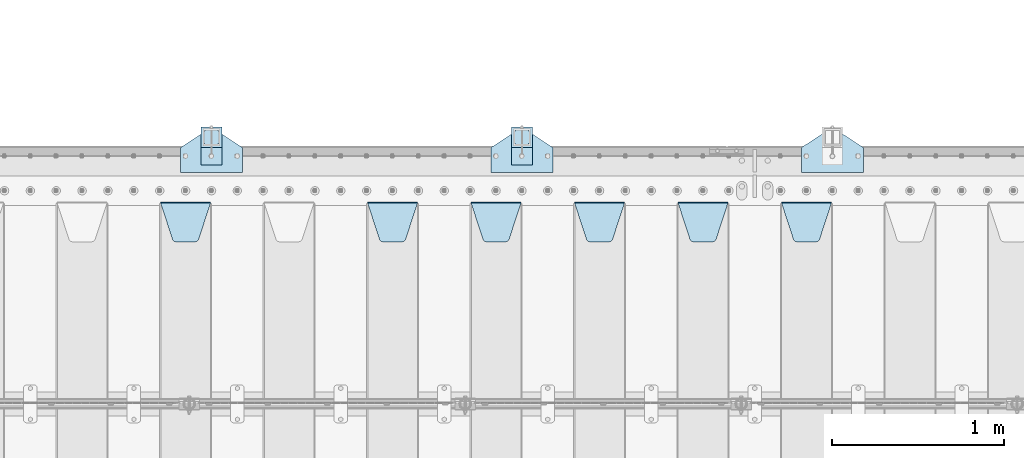
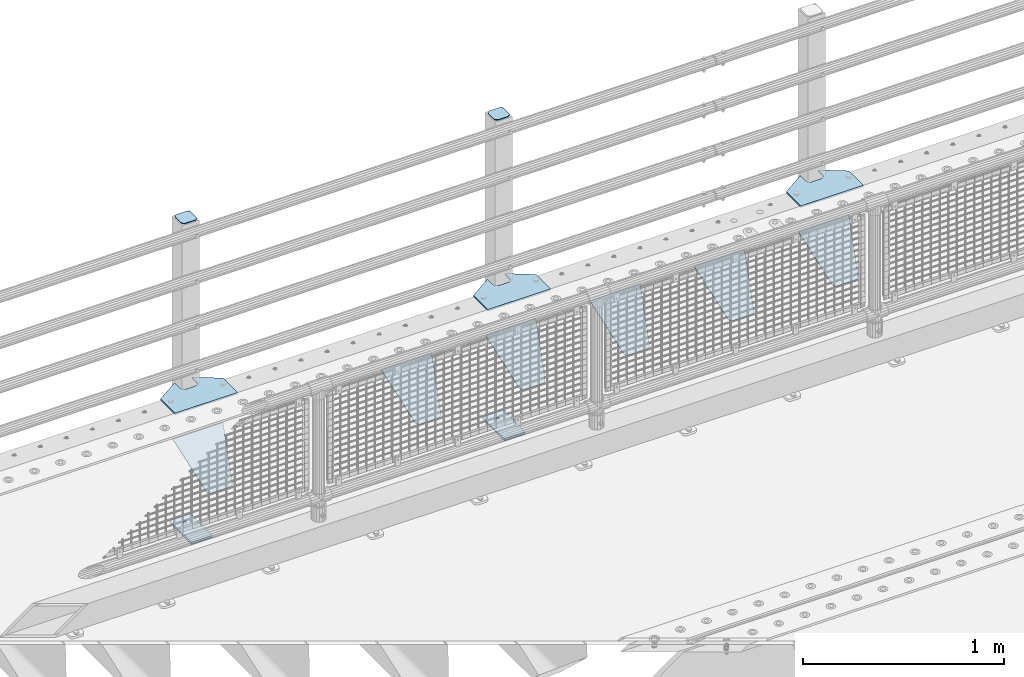
# One storey, part 223 of 257: 15 plates.
"""IFC2X3 building model written with IfcOpenShell, lengths in millimetres."""

from ifc_helpers import new_model, si_unit, frame, origin_with_axes, place, context, subcontext, project, spatial, faceted_brep, material, type_object, element, save


model = new_model("IFC2X3")

# Units and contexts
model_context = context("Model", 3, precision=1e-05, world=origin_with_axes())
body_context = subcontext(model_context, "Body", "Model", "MODEL_VIEW")
ifc_project = project(units=[si_unit("LENGTHUNIT", "METRE", prefix="MILLI"), si_unit("AREAUNIT", "SQUARE_METRE"), si_unit("VOLUMEUNIT", "CUBIC_METRE"), si_unit("MASSUNIT", "GRAM", prefix="KILO"), si_unit("TIMEUNIT", "SECOND"), si_unit("PLANEANGLEUNIT", "RADIAN"), si_unit("SOLIDANGLEUNIT", "STERADIAN"), si_unit("THERMODYNAMICTEMPERATUREUNIT", "DEGREE_CELSIUS"), si_unit("LUMINOUSINTENSITYUNIT", "LUMEN")], contexts=[model_context])

# Site, building, storey
site_placement = place(None, origin_with_axes())
site = spatial("IfcSite", under=ifc_project, at=site_placement, CompositionType="ELEMENT")
building_placement = place(site_placement, origin_with_axes())
building = spatial("IfcBuilding", under=site, at=building_placement, Name="Standard", CompositionType="ELEMENT")
storey_placement = place(building_placement, origin_with_axes())
storey = spatial("IfcBuildingStorey", under=building, at=storey_placement, Name="Undefined", CompositionType="ELEMENT", Elevation=0.0)

# Plates
ifc_material_1 = material(Name="STEEL/S355N")
plate_type_1 = type_object("IfcPlateType", PredefinedType="NOTDEFINED")
plate_1_placement = place(storey_placement, frame((48105.0, 11831.7677669559, -1.767766952965), z_axis=(0.0, -0.707106781186548, -0.707106781186547), x_axis=(1.0, 0.0, 0.0)))
element("IfcPlate", 1, at=plate_1_placement, inside=storey, type_object=plate_type_1, material=ifc_material_1, context=body_context, shape_type="Brep", body=[
    faceted_brep([(0.0, -2.5, 0.0), (69.345504679477, -2.50000000000091, 300.17173142483), (69.345504679477, 2.5, 300.171731424831), (0.0, 2.5, 0.0), (70.927406119954, -2.50000000000091, 304.8974424154), (70.927406119954, 2.5, 304.8974424154), (73.3818627772271, -2.50000000000091, 309.234538108527), (73.3818627772271, 2.49999999999909, 309.234538108527), (76.6187032999587, -2.5, 313.023683126103), (76.6187032999587, 2.5, 313.023683126103), (80.5190132705029, -2.5, 316.125672595372), (80.5190132705029, 2.5, 316.125672595371), (84.9395038596849, -2.5, 318.426546230476), (84.9395038596849, 2.5, 318.426546230477), (89.7177759439219, -2.5, 319.841774983275), (89.7177759439219, 2.5, 319.841774983275), (94.6782862926484, -2.5, 320.319366455079), (94.6782862926484, 2.5, 320.319366455079), (195.321713707352, -2.5, 320.319366455079), (195.321713707352, 2.5, 320.319366455079), (200.282224056078, -2.5, 319.841774983275), (200.282224056078, 2.49999999999909, 319.841774983275), (205.060496140315, -2.5, 318.426546230476), (205.060496140315, 2.49999999999909, 318.426546230475), (209.480986729497, -2.5, 316.125672595371), (209.480986729497, 2.5, 316.125672595371), (213.381296700041, -2.50000000000091, 313.023683126102), (213.381296700041, 2.5, 313.023683126103), (216.618137222766, -2.50000000000091, 309.234538108527), (216.618137222766, 2.5, 309.234538108527), (219.072593880039, -2.5, 304.897442415399), (219.072593880039, 2.5, 304.897442415399), (220.654495320523, -2.50000000000091, 300.17173142483), (220.654495320523, 2.5, 300.171731424831), (290.0, -2.50000000000091, 0.0), (290.0, 2.5, 9.09494701772928e-13)], [[[0, 1, 2, 3]], [[1, 4, 5, 2]], [[4, 6, 7, 5]], [[6, 8, 9, 7]], [[8, 10, 11, 9]], [[10, 12, 13, 11]], [[12, 14, 15, 13]], [[14, 16, 17, 15]], [[16, 18, 19, 17]], [[18, 20, 21, 19]], [[20, 22, 23, 21]], [[22, 24, 25, 23]], [[24, 26, 27, 25]], [[26, 28, 29, 27]], [[28, 30, 31, 29]], [[30, 32, 33, 31]], [[32, 34, 35, 33]], [[34, 0, 3, 35]], [[5, 7, 9, 11, 13, 15, 17, 19, 21, 23, 25, 27, 29, 31, 33, 35, 3, 2]], [[34, 32, 30, 28, 26, 24, 22, 20, 18, 16, 14, 12, 10, 8, 6, 4, 1, 0]]]),
])
plate_2_placement = place(storey_placement, frame((47505.0, 11831.7677669559, -1.767766952965), z_axis=(0.0, -0.707106781186548, -0.707106781186547), x_axis=(1.0, 0.0, 0.0)))
element("IfcPlate", 2, at=plate_2_placement, inside=storey, type_object=plate_type_1, material=ifc_material_1, context=body_context, shape_type="Brep", body=[
    faceted_brep([(0.0, -2.5, 0.0), (69.345504679477, -2.50000000000091, 300.17173142483), (69.345504679477, 2.5, 300.171731424831), (0.0, 2.5, 0.0), (70.927406119954, -2.50000000000091, 304.8974424154), (70.927406119954, 2.5, 304.8974424154), (73.3818627772271, -2.50000000000091, 309.234538108527), (73.3818627772271, 2.49999999999909, 309.234538108527), (76.6187032999587, -2.5, 313.023683126103), (76.6187032999587, 2.5, 313.023683126103), (80.5190132705029, -2.5, 316.125672595372), (80.5190132705029, 2.5, 316.125672595371), (84.9395038596849, -2.5, 318.426546230476), (84.9395038596849, 2.5, 318.426546230477), (89.7177759439219, -2.5, 319.841774983275), (89.7177759439219, 2.5, 319.841774983275), (94.6782862926484, -2.5, 320.319366455079), (94.6782862926484, 2.5, 320.319366455079), (195.321713707352, -2.5, 320.319366455079), (195.321713707352, 2.5, 320.319366455079), (200.282224056078, -2.5, 319.841774983275), (200.282224056078, 2.49999999999909, 319.841774983275), (205.060496140315, -2.5, 318.426546230476), (205.060496140315, 2.49999999999909, 318.426546230475), (209.480986729497, -2.5, 316.125672595371), (209.480986729497, 2.5, 316.125672595371), (213.381296700041, -2.50000000000091, 313.023683126102), (213.381296700041, 2.5, 313.023683126103), (216.618137222766, -2.50000000000091, 309.234538108527), (216.618137222766, 2.5, 309.234538108527), (219.072593880039, -2.5, 304.897442415399), (219.072593880039, 2.5, 304.897442415399), (220.654495320523, -2.50000000000091, 300.17173142483), (220.654495320523, 2.5, 300.171731424831), (290.0, -2.50000000000091, 0.0), (290.0, 2.5, 9.09494701772928e-13)], [[[0, 1, 2, 3]], [[1, 4, 5, 2]], [[4, 6, 7, 5]], [[6, 8, 9, 7]], [[8, 10, 11, 9]], [[10, 12, 13, 11]], [[12, 14, 15, 13]], [[14, 16, 17, 15]], [[16, 18, 19, 17]], [[18, 20, 21, 19]], [[20, 22, 23, 21]], [[22, 24, 25, 23]], [[24, 26, 27, 25]], [[26, 28, 29, 27]], [[28, 30, 31, 29]], [[30, 32, 33, 31]], [[32, 34, 35, 33]], [[34, 0, 3, 35]], [[5, 7, 9, 11, 13, 15, 17, 19, 21, 23, 25, 27, 29, 31, 33, 35, 3, 2]], [[34, 32, 30, 28, 26, 24, 22, 20, 18, 16, 14, 12, 10, 8, 6, 4, 1, 0]]]),
])
plate_3_placement = place(storey_placement, frame((46905.0, 11831.7677669559, -1.767766952965), z_axis=(0.0, -0.707106781186548, -0.707106781186547), x_axis=(1.0, 0.0, 0.0)))
element("IfcPlate", 3, at=plate_3_placement, inside=storey, type_object=plate_type_1, material=ifc_material_1, context=body_context, shape_type="Brep", body=[
    faceted_brep([(0.0, -2.5, 0.0), (69.345504679477, -2.50000000000091, 300.17173142483), (69.345504679477, 2.5, 300.171731424831), (0.0, 2.5, 0.0), (70.927406119954, -2.50000000000091, 304.8974424154), (70.927406119954, 2.5, 304.8974424154), (73.3818627772271, -2.50000000000091, 309.234538108527), (73.3818627772271, 2.49999999999909, 309.234538108527), (76.6187032999587, -2.5, 313.023683126103), (76.6187032999587, 2.5, 313.023683126103), (80.5190132705029, -2.5, 316.125672595372), (80.5190132705029, 2.5, 316.125672595371), (84.9395038596849, -2.5, 318.426546230476), (84.9395038596849, 2.5, 318.426546230477), (89.7177759439219, -2.5, 319.841774983275), (89.7177759439219, 2.5, 319.841774983275), (94.6782862926484, -2.5, 320.319366455079), (94.6782862926484, 2.5, 320.319366455079), (195.321713707352, -2.5, 320.319366455079), (195.321713707352, 2.5, 320.319366455079), (200.282224056078, -2.5, 319.841774983275), (200.282224056078, 2.49999999999909, 319.841774983275), (205.060496140315, -2.5, 318.426546230476), (205.060496140315, 2.49999999999909, 318.426546230475), (209.480986729497, -2.5, 316.125672595371), (209.480986729497, 2.5, 316.125672595371), (213.381296700041, -2.50000000000091, 313.023683126102), (213.381296700041, 2.5, 313.023683126103), (216.618137222766, -2.50000000000091, 309.234538108527), (216.618137222766, 2.5, 309.234538108527), (219.072593880039, -2.5, 304.897442415399), (219.072593880039, 2.5, 304.897442415399), (220.654495320523, -2.50000000000091, 300.17173142483), (220.654495320523, 2.5, 300.171731424831), (290.0, -2.50000000000091, 0.0), (290.0, 2.5, 9.09494701772928e-13)], [[[0, 1, 2, 3]], [[1, 4, 5, 2]], [[4, 6, 7, 5]], [[6, 8, 9, 7]], [[8, 10, 11, 9]], [[10, 12, 13, 11]], [[12, 14, 15, 13]], [[14, 16, 17, 15]], [[16, 18, 19, 17]], [[18, 20, 21, 19]], [[20, 22, 23, 21]], [[22, 24, 25, 23]], [[24, 26, 27, 25]], [[26, 28, 29, 27]], [[28, 30, 31, 29]], [[30, 32, 33, 31]], [[32, 34, 35, 33]], [[34, 0, 3, 35]], [[5, 7, 9, 11, 13, 15, 17, 19, 21, 23, 25, 27, 29, 31, 33, 35, 3, 2]], [[34, 32, 30, 28, 26, 24, 22, 20, 18, 16, 14, 12, 10, 8, 6, 4, 1, 0]]]),
])
plate_4_placement = place(storey_placement, frame((46305.0, 11831.7677669559, -1.767766952965), z_axis=(0.0, -0.707106781186548, -0.707106781186547), x_axis=(1.0, 0.0, 0.0)))
element("IfcPlate", 4, at=plate_4_placement, inside=storey, type_object=plate_type_1, material=ifc_material_1, context=body_context, shape_type="Brep", body=[
    faceted_brep([(0.0, -2.5, 0.0), (69.345504679477, -2.50000000000091, 300.17173142483), (69.345504679477, 2.5, 300.171731424831), (0.0, 2.5, 0.0), (70.927406119954, -2.50000000000091, 304.8974424154), (70.927406119954, 2.5, 304.8974424154), (73.3818627772271, -2.50000000000091, 309.234538108527), (73.3818627772271, 2.49999999999909, 309.234538108527), (76.6187032999587, -2.5, 313.023683126103), (76.6187032999587, 2.5, 313.023683126103), (80.5190132705029, -2.5, 316.125672595372), (80.5190132705029, 2.5, 316.125672595371), (84.9395038596849, -2.5, 318.426546230476), (84.9395038596849, 2.5, 318.426546230477), (89.7177759439219, -2.5, 319.841774983275), (89.7177759439219, 2.5, 319.841774983275), (94.6782862926484, -2.5, 320.319366455079), (94.6782862926484, 2.5, 320.319366455079), (195.321713707352, -2.5, 320.319366455079), (195.321713707352, 2.5, 320.319366455079), (200.282224056078, -2.5, 319.841774983275), (200.282224056078, 2.49999999999909, 319.841774983275), (205.060496140315, -2.5, 318.426546230476), (205.060496140315, 2.49999999999909, 318.426546230475), (209.480986729497, -2.5, 316.125672595371), (209.480986729497, 2.5, 316.125672595371), (213.381296700041, -2.50000000000091, 313.023683126102), (213.381296700041, 2.5, 313.023683126103), (216.618137222766, -2.50000000000091, 309.234538108527), (216.618137222766, 2.5, 309.234538108527), (219.072593880039, -2.5, 304.897442415399), (219.072593880039, 2.5, 304.897442415399), (220.654495320523, -2.50000000000091, 300.17173142483), (220.654495320523, 2.5, 300.171731424831), (290.0, -2.50000000000091, 0.0), (290.0, 2.5, 9.09494701772928e-13)], [[[0, 1, 2, 3]], [[1, 4, 5, 2]], [[4, 6, 7, 5]], [[6, 8, 9, 7]], [[8, 10, 11, 9]], [[10, 12, 13, 11]], [[12, 14, 15, 13]], [[14, 16, 17, 15]], [[16, 18, 19, 17]], [[18, 20, 21, 19]], [[20, 22, 23, 21]], [[22, 24, 25, 23]], [[24, 26, 27, 25]], [[26, 28, 29, 27]], [[28, 30, 31, 29]], [[30, 32, 33, 31]], [[32, 34, 35, 33]], [[34, 0, 3, 35]], [[5, 7, 9, 11, 13, 15, 17, 19, 21, 23, 25, 27, 29, 31, 33, 35, 3, 2]], [[34, 32, 30, 28, 26, 24, 22, 20, 18, 16, 14, 12, 10, 8, 6, 4, 1, 0]]]),
])
plate_5_placement = place(storey_placement, frame((45705.0, 11831.7677669559, -1.767766952965), z_axis=(0.0, -0.707106781186548, -0.707106781186547), x_axis=(1.0, 0.0, 0.0)))
element("IfcPlate", 5, at=plate_5_placement, inside=storey, type_object=plate_type_1, material=ifc_material_1, context=body_context, shape_type="Brep", body=[
    faceted_brep([(0.0, -2.5, 0.0), (69.345504679477, -2.50000000000091, 300.17173142483), (69.345504679477, 2.5, 300.171731424831), (0.0, 2.5, 0.0), (70.927406119954, -2.50000000000091, 304.8974424154), (70.927406119954, 2.5, 304.8974424154), (73.3818627772271, -2.50000000000091, 309.234538108527), (73.3818627772271, 2.49999999999909, 309.234538108527), (76.6187032999587, -2.5, 313.023683126103), (76.6187032999587, 2.5, 313.023683126103), (80.5190132705029, -2.5, 316.125672595372), (80.5190132705029, 2.5, 316.125672595371), (84.9395038596849, -2.5, 318.426546230476), (84.9395038596849, 2.5, 318.426546230477), (89.7177759439219, -2.5, 319.841774983275), (89.7177759439219, 2.5, 319.841774983275), (94.6782862926484, -2.5, 320.319366455079), (94.6782862926484, 2.5, 320.319366455079), (195.321713707352, -2.5, 320.319366455079), (195.321713707352, 2.5, 320.319366455079), (200.282224056078, -2.5, 319.841774983275), (200.282224056078, 2.49999999999909, 319.841774983275), (205.060496140315, -2.5, 318.426546230476), (205.060496140315, 2.49999999999909, 318.426546230475), (209.480986729497, -2.5, 316.125672595371), (209.480986729497, 2.5, 316.125672595371), (213.381296700041, -2.50000000000091, 313.023683126102), (213.381296700041, 2.5, 313.023683126103), (216.618137222766, -2.50000000000091, 309.234538108527), (216.618137222766, 2.5, 309.234538108527), (219.072593880039, -2.5, 304.897442415399), (219.072593880039, 2.5, 304.897442415399), (220.654495320523, -2.50000000000091, 300.17173142483), (220.654495320523, 2.5, 300.171731424831), (290.0, -2.50000000000091, 0.0), (290.0, 2.5, 9.09494701772928e-13)], [[[0, 1, 2, 3]], [[1, 4, 5, 2]], [[4, 6, 7, 5]], [[6, 8, 9, 7]], [[8, 10, 11, 9]], [[10, 12, 13, 11]], [[12, 14, 15, 13]], [[14, 16, 17, 15]], [[16, 18, 19, 17]], [[18, 20, 21, 19]], [[20, 22, 23, 21]], [[22, 24, 25, 23]], [[24, 26, 27, 25]], [[26, 28, 29, 27]], [[28, 30, 31, 29]], [[30, 32, 33, 31]], [[32, 34, 35, 33]], [[34, 0, 3, 35]], [[5, 7, 9, 11, 13, 15, 17, 19, 21, 23, 25, 27, 29, 31, 33, 35, 3, 2]], [[34, 32, 30, 28, 26, 24, 22, 20, 18, 16, 14, 12, 10, 8, 6, 4, 1, 0]]]),
])
plate_6_placement = place(storey_placement, frame((44505.0, 11831.7677669559, -1.767766952965), z_axis=(0.0, -0.707106781186548, -0.707106781186547), x_axis=(1.0, 0.0, 0.0)))
element("IfcPlate", 6, at=plate_6_placement, inside=storey, type_object=plate_type_1, material=ifc_material_1, context=body_context, shape_type="Brep", body=[
    faceted_brep([(0.0, -2.5, 0.0), (69.345504679477, -2.50000000000091, 300.17173142483), (69.345504679477, 2.5, 300.171731424831), (0.0, 2.5, 0.0), (70.927406119954, -2.50000000000091, 304.8974424154), (70.927406119954, 2.5, 304.8974424154), (73.3818627772271, -2.50000000000091, 309.234538108527), (73.3818627772271, 2.49999999999909, 309.234538108527), (76.6187032999587, -2.5, 313.023683126103), (76.6187032999587, 2.5, 313.023683126103), (80.5190132705029, -2.5, 316.125672595372), (80.5190132705029, 2.5, 316.125672595371), (84.9395038596849, -2.5, 318.426546230476), (84.9395038596849, 2.5, 318.426546230477), (89.7177759439219, -2.5, 319.841774983275), (89.7177759439219, 2.5, 319.841774983275), (94.6782862926484, -2.5, 320.319366455079), (94.6782862926484, 2.5, 320.319366455079), (195.321713707352, -2.5, 320.319366455079), (195.321713707352, 2.5, 320.319366455079), (200.282224056078, -2.5, 319.841774983275), (200.282224056078, 2.49999999999909, 319.841774983275), (205.060496140315, -2.5, 318.426546230476), (205.060496140315, 2.49999999999909, 318.426546230475), (209.480986729497, -2.5, 316.125672595371), (209.480986729497, 2.5, 316.125672595371), (213.381296700041, -2.50000000000091, 313.023683126102), (213.381296700041, 2.5, 313.023683126103), (216.618137222766, -2.50000000000091, 309.234538108527), (216.618137222766, 2.5, 309.234538108527), (219.072593880039, -2.5, 304.897442415399), (219.072593880039, 2.5, 304.897442415399), (220.654495320523, -2.50000000000091, 300.17173142483), (220.654495320523, 2.5, 300.171731424831), (290.0, -2.50000000000091, 0.0), (290.0, 2.5, 9.09494701772928e-13)], [[[0, 1, 2, 3]], [[1, 4, 5, 2]], [[4, 6, 7, 5]], [[6, 8, 9, 7]], [[8, 10, 11, 9]], [[10, 12, 13, 11]], [[12, 14, 15, 13]], [[14, 16, 17, 15]], [[16, 18, 19, 17]], [[18, 20, 21, 19]], [[20, 22, 23, 21]], [[22, 24, 25, 23]], [[24, 26, 27, 25]], [[26, 28, 29, 27]], [[28, 30, 31, 29]], [[30, 32, 33, 31]], [[32, 34, 35, 33]], [[34, 0, 3, 35]], [[5, 7, 9, 11, 13, 15, 17, 19, 21, 23, 25, 27, 29, 31, 33, 35, 3, 2]], [[34, 32, 30, 28, 26, 24, 22, 20, 18, 16, 14, 12, 10, 8, 6, 4, 1, 0]]]),
])
ifc_material_2 = material(Name="STEEL/S355J2")
plate_type_2 = type_object("IfcPlateType", PredefinedType="NOTDEFINED")
plate_7_placement = place(storey_placement, frame((48220.0, 12005.0, 5.00000000004911), z_axis=(0.0, 1.0, 0.0), x_axis=(1.0, 0.0, 0.0)))
element("IfcPlate", 7, at=plate_7_placement, inside=storey, type_object=plate_type_2, material=ifc_material_2, context=body_context, shape_type="Brep", body=[
    faceted_brep([(0.0, -5.0, 0.0), (2.31396552408114e-06, -5.0, 145.0), (2.31396552408114e-06, 5.0, 145.0), (0.0, 5.0, 0.0), (130.0, -5.0, 230.0), (130.0, 5.0, 230.0), (130.0, -5.0, 180.0), (130.0, 5.0, 180.0), (130.48036798992, -5.0, 175.122741949597), (130.48036798992, 5.0, 175.122741949597), (131.903011687216, -5.0, 170.432914190873), (131.903011687216, 5.0, 170.432914190873), (134.213259692435, -5.0, 166.11074417451), (134.213259692435, 5.0, 166.11074417451), (137.322330470335, -5.0, 162.322330470337), (137.322330470335, 5.0, 162.322330470337), (141.110744174512, -5.0, 159.213259692437), (141.110744174512, 5.0, 159.213259692437), (145.432914190875, -5.0, 156.903011687218), (145.432914190875, 5.0, 156.903011687218), (150.122741949599, -5.0, 155.48036798992), (150.122741949599, 5.0, 155.48036798992), (155.0, -5.0, 155.0), (155.0, 5.0, 155.0), (205.0, -5.0, 155.0), (205.0, 5.0, 155.0), (209.877258050401, -5.0, 155.48036798992), (209.877258050401, 5.0, 155.48036798992), (214.567085809125, -5.0, 156.903011687218), (214.567085809125, 5.0, 156.903011687218), (218.889255825488, -5.0, 159.213259692437), (218.889255825488, 5.0, 159.213259692437), (222.677669529665, -5.0, 162.322330470337), (222.677669529665, 5.0, 162.322330470337), (225.786740307565, -5.0, 166.11074417451), (225.786740307565, 5.0, 166.11074417451), (228.096988312784, -5.0, 170.432914190873), (228.096988312784, 5.0, 170.432914190873), (229.51963201008, -5.0, 175.122741949597), (229.51963201008, 5.0, 175.122741949597), (230.0, -5.0, 180.0), (230.0, 5.0, 180.0), (230.0, -5.0, 230.0), (230.0, 5.0, 230.0), (360.0, -5.0, 145.0), (360.0, 5.0, 145.0), (360.0, -5.0, -7.27595761418343e-12), (360.0, 5.0, -7.27595761418343e-12)], [[[0, 1, 2, 3]], [[1, 4, 5, 2]], [[4, 6, 7, 5]], [[6, 8, 9, 7]], [[8, 10, 11, 9]], [[10, 12, 13, 11]], [[12, 14, 15, 13]], [[14, 16, 17, 15]], [[16, 18, 19, 17]], [[18, 20, 21, 19]], [[20, 22, 23, 21]], [[22, 24, 25, 23]], [[24, 26, 27, 25]], [[26, 28, 29, 27]], [[28, 30, 31, 29]], [[30, 32, 33, 31]], [[32, 34, 35, 33]], [[34, 36, 37, 35]], [[36, 38, 39, 37]], [[38, 40, 41, 39]], [[40, 42, 43, 41]], [[42, 44, 45, 43]], [[44, 46, 47, 45]], [[46, 0, 3, 47]], [[5, 7, 9, 11, 13, 15, 17, 19, 21, 23, 25, 27, 29, 31, 33, 35, 37, 39, 41, 43, 45, 47, 3, 2]], [[46, 44, 42, 40, 38, 36, 34, 32, 30, 28, 26, 24, 22, 20, 18, 16, 14, 12, 10, 8, 6, 4, 1, 0]]]),
])
plate_8_placement = place(storey_placement, frame((46420.0, 12005.0, 5.00000000004911), z_axis=(0.0, 1.0, 0.0), x_axis=(1.0, 0.0, 0.0)))
element("IfcPlate", 8, at=plate_8_placement, inside=storey, type_object=plate_type_2, material=ifc_material_2, context=body_context, shape_type="Brep", body=[
    faceted_brep([(0.0, -5.0, 0.0), (2.31396552408114e-06, -5.0, 145.0), (2.31396552408114e-06, 5.0, 145.0), (0.0, 5.0, 0.0), (130.0, -5.0, 230.0), (130.0, 5.0, 230.0), (130.0, -5.0, 180.0), (130.0, 5.0, 180.0), (130.48036798992, -5.0, 175.122741949597), (130.48036798992, 5.0, 175.122741949597), (131.903011687216, -5.0, 170.432914190873), (131.903011687216, 5.0, 170.432914190873), (134.213259692435, -5.0, 166.11074417451), (134.213259692435, 5.0, 166.11074417451), (137.322330470335, -5.0, 162.322330470337), (137.322330470335, 5.0, 162.322330470337), (141.110744174512, -5.0, 159.213259692437), (141.110744174512, 5.0, 159.213259692437), (145.432914190875, -5.0, 156.903011687218), (145.432914190875, 5.0, 156.903011687218), (150.122741949599, -5.0, 155.48036798992), (150.122741949599, 5.0, 155.48036798992), (155.0, -5.0, 155.0), (155.0, 5.0, 155.0), (205.0, -5.0, 155.0), (205.0, 5.0, 155.0), (209.877258050401, -5.0, 155.48036798992), (209.877258050401, 5.0, 155.48036798992), (214.567085809125, -5.0, 156.903011687218), (214.567085809125, 5.0, 156.903011687218), (218.889255825488, -5.0, 159.213259692437), (218.889255825488, 5.0, 159.213259692437), (222.677669529665, -5.0, 162.322330470337), (222.677669529665, 5.0, 162.322330470337), (225.786740307565, -5.0, 166.11074417451), (225.786740307565, 5.0, 166.11074417451), (228.096988312784, -5.0, 170.432914190873), (228.096988312784, 5.0, 170.432914190873), (229.51963201008, -5.0, 175.122741949597), (229.51963201008, 5.0, 175.122741949597), (230.0, -5.0, 180.0), (230.0, 5.0, 180.0), (230.0, -5.0, 230.0), (230.0, 5.0, 230.0), (360.0, -5.0, 145.0), (360.0, 5.0, 145.0), (360.0, -5.0, -7.27595761418343e-12), (360.0, 5.0, -7.27595761418343e-12)], [[[0, 1, 2, 3]], [[1, 4, 5, 2]], [[4, 6, 7, 5]], [[6, 8, 9, 7]], [[8, 10, 11, 9]], [[10, 12, 13, 11]], [[12, 14, 15, 13]], [[14, 16, 17, 15]], [[16, 18, 19, 17]], [[18, 20, 21, 19]], [[20, 22, 23, 21]], [[22, 24, 25, 23]], [[24, 26, 27, 25]], [[26, 28, 29, 27]], [[28, 30, 31, 29]], [[30, 32, 33, 31]], [[32, 34, 35, 33]], [[34, 36, 37, 35]], [[36, 38, 39, 37]], [[38, 40, 41, 39]], [[40, 42, 43, 41]], [[42, 44, 45, 43]], [[44, 46, 47, 45]], [[46, 0, 3, 47]], [[5, 7, 9, 11, 13, 15, 17, 19, 21, 23, 25, 27, 29, 31, 33, 35, 37, 39, 41, 43, 45, 47, 3, 2]], [[46, 44, 42, 40, 38, 36, 34, 32, 30, 28, 26, 24, 22, 20, 18, 16, 14, 12, 10, 8, 6, 4, 1, 0]]]),
])
plate_9_placement = place(storey_placement, frame((44620.0, 12005.0, 5.00000000004911), z_axis=(0.0, 1.0, 0.0), x_axis=(1.0, 0.0, 0.0)))
element("IfcPlate", 9, at=plate_9_placement, inside=storey, type_object=plate_type_2, material=ifc_material_2, context=body_context, shape_type="Brep", body=[
    faceted_brep([(0.0, -5.0, 0.0), (2.31396552408114e-06, -5.0, 145.0), (2.31396552408114e-06, 5.0, 145.0), (0.0, 5.0, 0.0), (130.0, -5.0, 230.0), (130.0, 5.0, 230.0), (130.0, -5.0, 180.0), (130.0, 5.0, 180.0), (130.48036798992, -5.0, 175.122741949597), (130.48036798992, 5.0, 175.122741949597), (131.903011687216, -5.0, 170.432914190873), (131.903011687216, 5.0, 170.432914190873), (134.213259692435, -5.0, 166.11074417451), (134.213259692435, 5.0, 166.11074417451), (137.322330470335, -5.0, 162.322330470337), (137.322330470335, 5.0, 162.322330470337), (141.110744174512, -5.0, 159.213259692437), (141.110744174512, 5.0, 159.213259692437), (145.432914190875, -5.0, 156.903011687218), (145.432914190875, 5.0, 156.903011687218), (150.122741949599, -5.0, 155.48036798992), (150.122741949599, 5.0, 155.48036798992), (155.0, -5.0, 155.0), (155.0, 5.0, 155.0), (205.0, -5.0, 155.0), (205.0, 5.0, 155.0), (209.877258050401, -5.0, 155.48036798992), (209.877258050401, 5.0, 155.48036798992), (214.567085809125, -5.0, 156.903011687218), (214.567085809125, 5.0, 156.903011687218), (218.889255825488, -5.0, 159.213259692437), (218.889255825488, 5.0, 159.213259692437), (222.677669529665, -5.0, 162.322330470337), (222.677669529665, 5.0, 162.322330470337), (225.786740307565, -5.0, 166.11074417451), (225.786740307565, 5.0, 166.11074417451), (228.096988312784, -5.0, 170.432914190873), (228.096988312784, 5.0, 170.432914190873), (229.51963201008, -5.0, 175.122741949597), (229.51963201008, 5.0, 175.122741949597), (230.0, -5.0, 180.0), (230.0, 5.0, 180.0), (230.0, -5.0, 230.0), (230.0, 5.0, 230.0), (360.0, -5.0, 145.0), (360.0, 5.0, 145.0), (360.0, -5.0, -7.27595761418343e-12), (360.0, 5.0, -7.27595761418343e-12)], [[[0, 1, 2, 3]], [[1, 4, 5, 2]], [[4, 6, 7, 5]], [[6, 8, 9, 7]], [[8, 10, 11, 9]], [[10, 12, 13, 11]], [[12, 14, 15, 13]], [[14, 16, 17, 15]], [[16, 18, 19, 17]], [[18, 20, 21, 19]], [[20, 22, 23, 21]], [[22, 24, 25, 23]], [[24, 26, 27, 25]], [[26, 28, 29, 27]], [[28, 30, 31, 29]], [[30, 32, 33, 31]], [[32, 34, 35, 33]], [[34, 36, 37, 35]], [[36, 38, 39, 37]], [[38, 40, 41, 39]], [[40, 42, 43, 41]], [[42, 44, 45, 43]], [[44, 46, 47, 45]], [[46, 0, 3, 47]], [[5, 7, 9, 11, 13, 15, 17, 19, 21, 23, 25, 27, 29, 31, 33, 35, 37, 39, 41, 43, 45, 47, 3, 2]], [[46, 44, 42, 40, 38, 36, 34, 32, 30, 28, 26, 24, 22, 20, 18, 16, 14, 12, 10, 8, 6, 4, 1, 0]]]),
])
plate_type_3 = type_object("IfcPlateType", PredefinedType="NOTDEFINED")
for number, where, z_axis, x_axis in (
    (10, (46540.0000000001, 12050.0000000002, -850.000000000002), (0.0, 1.0, 0.0), (1.0, 0.0, 0.0)),
    (11, (44740.0000000001, 12050.0000000002, -850.000000000002), (0.0, 1.0, 0.0), (1.0, 0.0, 0.0)),
):
    element("IfcPlate", number, at=place(storey_placement, frame(where, z_axis=z_axis, x_axis=x_axis)), inside=storey, type_object=plate_type_3, material=ifc_material_2, context=body_context, shape_type="Brep", body=[
        faceted_brep([(66.3639610305399, -5.0, 163.636038969113), (66.3639610305399, 5.0, 163.636038969113), (59.9999999998618, 5.0, 160.999999999791), (59.9999999998618, -5.0, 160.999999999791), (53.6360389691836, 5.0, 163.636038969113), (53.6360389691836, -5.0, 163.636038969113), (50.9999999998618, 5.0, 169.999999999791), (50.9999999998618, -5.0, 169.999999999791), (53.6360389691836, 5.0, 176.363961030469), (53.6360389691836, -5.0, 176.363961030469), (59.9999999998618, 5.0, 178.999999999791), (59.9999999998618, -5.0, 178.999999999791), (66.3639610305399, 5.0, 176.363961030469), (66.3639610305399, -5.0, 176.363961030469), (68.9999999998618, 5.0, 169.999999999791), (68.9999999998618, -5.0, 169.999999999791), (120.0, -5.0, 0.0), (120.0, -5.0, 220.0), (0.0, -5.0, 220.0), (0.0, -5.0, 0.0), (0.0, 5.0, 0.0), (120.0, 5.0, 0.0), (120.0, 5.0, 220.0), (0.0, 5.0, 220.0)], [[[0, 1, 2, 3]], [[3, 2, 4, 5]], [[5, 4, 6, 7]], [[7, 6, 8, 9]], [[9, 8, 10, 11]], [[11, 10, 12, 13]], [[13, 12, 14, 15]], [[15, 14, 1, 0]], [[16, 17, 18, 19], [3, 5, 7, 9, 11, 13, 15, 0]], [[16, 19, 20, 21]], [[17, 16, 21, 22]], [[18, 17, 22, 23]], [[19, 18, 23, 20]], [[22, 21, 20, 23], [10, 8, 6, 4, 2, 1, 14, 12]]]),
    ])
plate_type_4 = type_object("IfcPlateType", PredefinedType="NOTDEFINED")
plate_10_placement = place(storey_placement, frame((46644.0000000001, 12166.0000000002, 1012.50000000001), z_axis=(0.0, 1.0, 0.0), x_axis=(-1.0, 0.0, 0.0)))
element("IfcPlate", 12, at=plate_10_placement, inside=storey, type_object=plate_type_4, material=ifc_material_2, context=body_context, shape_type="Brep", body=[
    faceted_brep([(0.0, -2.5, 19.0), (0.0, -2.5, 69.0), (0.0, 2.5, 69.0), (0.0, 2.5, 19.0), (0.476369668547704, -2.5, 73.2278977451697), (0.476369668547704, 2.5, 73.2278977451697), (1.88159150985302, -2.5, 77.2437910432327), (1.88159150985302, 2.5, 77.2437910432327), (4.14520183311106, -2.5, 80.8463062353167), (4.14520183311106, 2.5, 80.8463062353167), (7.15369376468152, -2.5, 83.8547981668926), (7.15369376468152, 2.5, 83.8547981668926), (10.7562089567655, -2.5, 86.1184084901452), (10.7562089567655, 2.5, 86.1184084901452), (14.7721022548285, -2.5, 87.5236303314541), (14.7721022548285, 2.5, 87.5236303314541), (19.0, -2.5, 88.0), (19.0, 2.5, 88.0), (69.0, -2.5, 88.0), (69.0, 2.5, 88.0), (73.2278977451715, -2.5, 87.5236303314541), (73.2278977451715, 2.5, 87.5236303314541), (77.2437910432345, -2.5, 86.1184084901452), (77.2437910432345, 2.5, 86.1184084901452), (80.8463062353185, -2.5, 83.8547981668926), (80.8463062353185, 2.5, 83.8547981668926), (83.8547981668889, -2.5, 80.8463062353167), (83.8547981668889, 2.5, 80.8463062353167), (86.118408490147, -2.5, 77.2437910432327), (86.118408490147, 2.5, 77.2437910432327), (87.5236303314523, -2.5, 73.2278977451697), (87.5236303314523, 2.5, 73.2278977451697), (88.0, -2.5, 69.0), (88.0, 2.5, 69.0), (88.0, -2.5, 19.0), (88.0, 2.5, 19.0), (87.5236303314523, -2.5, 14.7721022548303), (87.5236303314523, 2.5, 14.7721022548303), (86.118408490147, -2.5, 10.7562089567673), (86.118408490147, 2.5, 10.7562089567673), (83.8547981668889, -2.5, 7.15369376468334), (83.8547981668889, 2.5, 7.15369376468334), (80.8463062353185, -2.5, 4.14520183310742), (80.8463062353185, 2.5, 4.14520183310742), (77.2437910432345, -2.5, 1.88159150985484), (77.2437910432345, 2.5, 1.88159150985484), (73.2278977451715, -2.5, 0.476369668545885), (73.2278977451715, 2.5, 0.476369668545885), (69.0, -2.5, 0.0), (69.0, 2.5, 0.0), (19.0, -2.5, 0.0), (19.0, 2.5, 0.0), (14.7721022548285, -2.5, 0.476369668545885), (14.7721022548285, 2.5, 0.476369668545885), (10.7562089567655, -2.5, 1.88159150985484), (10.7562089567655, 2.5, 1.88159150985484), (7.15369376468152, -2.5, 4.14520183310742), (7.15369376468152, 2.5, 4.14520183310742), (4.14520183311106, -2.5, 7.15369376468334), (4.14520183311106, 2.5, 7.15369376468334), (1.88159150985302, -2.5, 10.7562089567673), (1.88159150985302, 2.5, 10.7562089567673), (0.476369668547704, -2.5, 14.7721022548303), (0.476369668547704, 2.5, 14.7721022548303)], [[[0, 1, 2, 3]], [[1, 4, 5, 2]], [[4, 6, 7, 5]], [[6, 8, 9, 7]], [[8, 10, 11, 9]], [[10, 12, 13, 11]], [[12, 14, 15, 13]], [[14, 16, 17, 15]], [[16, 18, 19, 17]], [[18, 20, 21, 19]], [[20, 22, 23, 21]], [[22, 24, 25, 23]], [[24, 26, 27, 25]], [[26, 28, 29, 27]], [[28, 30, 31, 29]], [[30, 32, 33, 31]], [[32, 34, 35, 33]], [[34, 36, 37, 35]], [[36, 38, 39, 37]], [[38, 40, 41, 39]], [[40, 42, 43, 41]], [[42, 44, 45, 43]], [[44, 46, 47, 45]], [[46, 48, 49, 47]], [[48, 50, 51, 49]], [[50, 52, 53, 51]], [[52, 54, 55, 53]], [[54, 56, 57, 55]], [[56, 58, 59, 57]], [[58, 60, 61, 59]], [[60, 62, 63, 61]], [[62, 0, 3, 63]], [[5, 7, 9, 11, 13, 15, 17, 19, 21, 23, 25, 27, 29, 31, 33, 35, 37, 39, 41, 43, 45, 47, 49, 51, 53, 55, 57, 59, 61, 63, 3, 2]], [[62, 60, 58, 56, 54, 52, 50, 48, 46, 44, 42, 40, 38, 36, 34, 32, 30, 28, 26, 24, 22, 20, 18, 16, 14, 12, 10, 8, 6, 4, 1, 0]]]),
])
plate_11_placement = place(storey_placement, frame((44844.0000000001, 12166.0000000002, 1012.50000000001), z_axis=(0.0, 1.0, 0.0), x_axis=(-1.0, 0.0, 0.0)))
element("IfcPlate", 13, at=plate_11_placement, inside=storey, type_object=plate_type_4, material=ifc_material_2, context=body_context, shape_type="Brep", body=[
    faceted_brep([(0.0, -2.5, 19.0), (0.0, -2.5, 69.0), (0.0, 2.5, 69.0), (0.0, 2.5, 19.0), (0.476369668547704, -2.5, 73.2278977451697), (0.476369668547704, 2.5, 73.2278977451697), (1.88159150985302, -2.5, 77.2437910432327), (1.88159150985302, 2.5, 77.2437910432327), (4.14520183311106, -2.5, 80.8463062353167), (4.14520183311106, 2.5, 80.8463062353167), (7.15369376468152, -2.5, 83.8547981668926), (7.15369376468152, 2.5, 83.8547981668926), (10.7562089567655, -2.5, 86.1184084901452), (10.7562089567655, 2.5, 86.1184084901452), (14.7721022548285, -2.5, 87.5236303314541), (14.7721022548285, 2.5, 87.5236303314541), (19.0, -2.5, 88.0), (19.0, 2.5, 88.0), (69.0, -2.5, 88.0), (69.0, 2.5, 88.0), (73.2278977451715, -2.5, 87.5236303314541), (73.2278977451715, 2.5, 87.5236303314541), (77.2437910432345, -2.5, 86.1184084901452), (77.2437910432345, 2.5, 86.1184084901452), (80.8463062353185, -2.5, 83.8547981668926), (80.8463062353185, 2.5, 83.8547981668926), (83.8547981668889, -2.5, 80.8463062353167), (83.8547981668889, 2.5, 80.8463062353167), (86.118408490147, -2.5, 77.2437910432327), (86.118408490147, 2.5, 77.2437910432327), (87.5236303314523, -2.5, 73.2278977451697), (87.5236303314523, 2.5, 73.2278977451697), (88.0, -2.5, 69.0), (88.0, 2.5, 69.0), (88.0, -2.5, 19.0), (88.0, 2.5, 19.0), (87.5236303314523, -2.5, 14.7721022548303), (87.5236303314523, 2.5, 14.7721022548303), (86.118408490147, -2.5, 10.7562089567673), (86.118408490147, 2.5, 10.7562089567673), (83.8547981668889, -2.5, 7.15369376468334), (83.8547981668889, 2.5, 7.15369376468334), (80.8463062353185, -2.5, 4.14520183310742), (80.8463062353185, 2.5, 4.14520183310742), (77.2437910432345, -2.5, 1.88159150985484), (77.2437910432345, 2.5, 1.88159150985484), (73.2278977451715, -2.5, 0.476369668545885), (73.2278977451715, 2.5, 0.476369668545885), (69.0, -2.5, 0.0), (69.0, 2.5, 0.0), (19.0, -2.5, 0.0), (19.0, 2.5, 0.0), (14.7721022548285, -2.5, 0.476369668545885), (14.7721022548285, 2.5, 0.476369668545885), (10.7562089567655, -2.5, 1.88159150985484), (10.7562089567655, 2.5, 1.88159150985484), (7.15369376468152, -2.5, 4.14520183310742), (7.15369376468152, 2.5, 4.14520183310742), (4.14520183311106, -2.5, 7.15369376468334), (4.14520183311106, 2.5, 7.15369376468334), (1.88159150985302, -2.5, 10.7562089567673), (1.88159150985302, 2.5, 10.7562089567673), (0.476369668547704, -2.5, 14.7721022548303), (0.476369668547704, 2.5, 14.7721022548303)], [[[0, 1, 2, 3]], [[1, 4, 5, 2]], [[4, 6, 7, 5]], [[6, 8, 9, 7]], [[8, 10, 11, 9]], [[10, 12, 13, 11]], [[12, 14, 15, 13]], [[14, 16, 17, 15]], [[16, 18, 19, 17]], [[18, 20, 21, 19]], [[20, 22, 23, 21]], [[22, 24, 25, 23]], [[24, 26, 27, 25]], [[26, 28, 29, 27]], [[28, 30, 31, 29]], [[30, 32, 33, 31]], [[32, 34, 35, 33]], [[34, 36, 37, 35]], [[36, 38, 39, 37]], [[38, 40, 41, 39]], [[40, 42, 43, 41]], [[42, 44, 45, 43]], [[44, 46, 47, 45]], [[46, 48, 49, 47]], [[48, 50, 51, 49]], [[50, 52, 53, 51]], [[52, 54, 55, 53]], [[54, 56, 57, 55]], [[56, 58, 59, 57]], [[58, 60, 61, 59]], [[60, 62, 63, 61]], [[62, 0, 3, 63]], [[5, 7, 9, 11, 13, 15, 17, 19, 21, 23, 25, 27, 29, 31, 33, 35, 37, 39, 41, 43, 45, 47, 49, 51, 53, 55, 57, 59, 61, 63, 3, 2]], [[62, 60, 58, 56, 54, 52, 50, 48, 46, 44, 42, 40, 38, 36, 34, 32, 30, 28, 26, 24, 22, 20, 18, 16, 14, 12, 10, 8, 6, 4, 1, 0]]]),
])
plate_type_5 = type_object("IfcPlateType", PredefinedType="NOTDEFINED")
for number, where, z_axis, x_axis in (
    (14, (46540.0000000001, 12050.0000000002, -857.500000000002), (0.0, 1.0, 0.0), (1.0, 0.0, 0.0)),
    (15, (44740.0000000001, 12050.0000000002, -857.500000000002), (0.0, 1.0, 0.0), (1.0, 0.0, 0.0)),
):
    element("IfcPlate", number, at=place(storey_placement, frame(where, z_axis=z_axis, x_axis=x_axis)), inside=storey, type_object=plate_type_5, material=ifc_material_2, context=body_context, shape_type="Brep", body=[
        faceted_brep([(0.0, -2.5, 0.0), (0.0, -2.5, 100.0), (0.0, 2.5, 100.0), (0.0, 2.5, 0.0), (120.0, -2.5, 100.0), (120.0, 2.5, 100.0), (120.0, -2.5, 0.0), (120.0, 2.5, 0.0)], [[[0, 1, 2, 3]], [[1, 4, 5, 2]], [[4, 6, 7, 5]], [[6, 0, 3, 7]], [[5, 7, 3, 2]], [[6, 4, 1, 0]]]),
    ])

save(model, "model.ifc")
